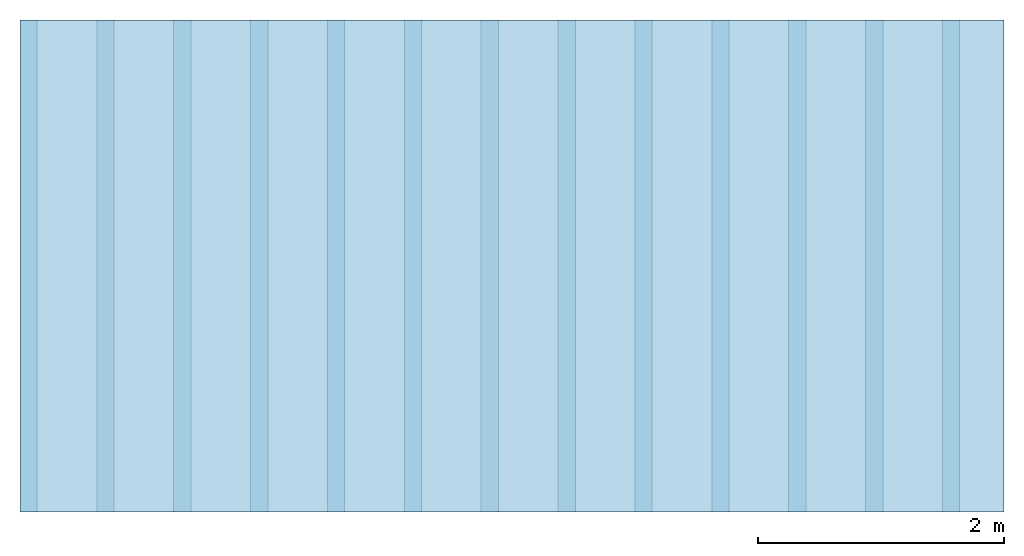
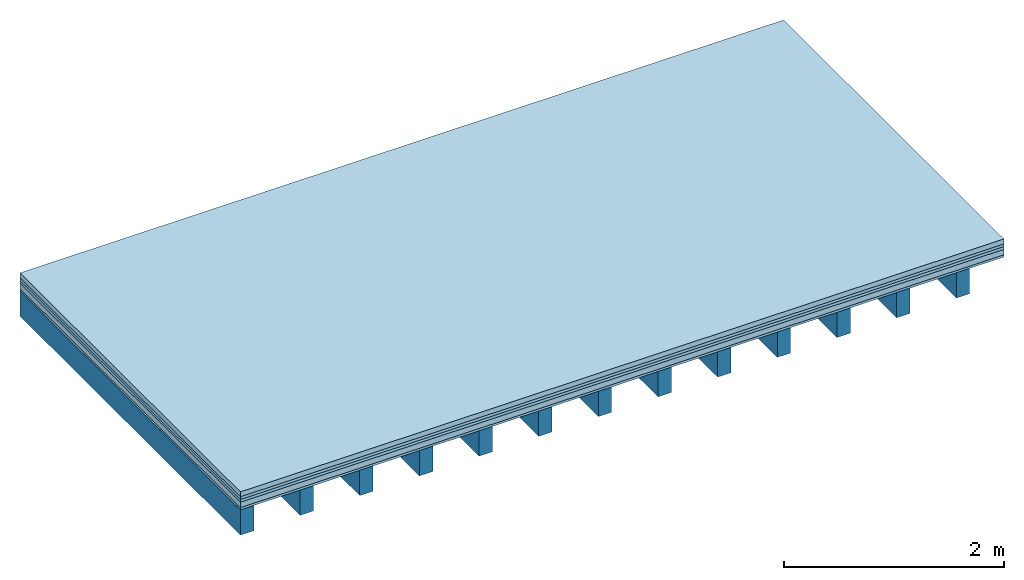
# One storey: 5 plates, 1 member, 1 element without a shape of its own.
"""IFC4 building model written with IfcOpenShell, lengths in metres."""

from ifc_helpers import new_model, si_unit, derived_unit, direction, frame, frame_2d, origin, origin_with_axes, place, context, project, spatial, rectangle, extrude, material, layer, layer_set, type_object, element, aggregate, save


model = new_model("IFC4")

# Units and contexts
plan_context = context("Plan", 3, precision=1e-05, world=origin(), true_north=direction((0.0, 1.0)))
model_context = context("Model", 3, precision=1e-05, world=origin(), true_north=direction((0.0, 1.0)))
ifc_project = project(units=[si_unit("LENGTHUNIT", "METRE"), derived_unit("SOUNDPRESSUREUNIT", [(si_unit("PRESSUREUNIT", "PASCAL", prefix="MICRO"), 0)]), si_unit("ENERGYUNIT", "JOULE", prefix="MEGA"), si_unit("MASSUNIT", "GRAM", prefix="KILO"), derived_unit("THERMALTRANSMITTANCEUNIT", [(si_unit("POWERUNIT", "WATT"), 1), (si_unit("AREAUNIT", "SQUARE_METRE"), -1), (si_unit("THERMODYNAMICTEMPERATUREUNIT", "KELVIN"), -1)]), derived_unit("AREADENSITYUNIT", [(si_unit("MASSUNIT", "GRAM", prefix="KILO"), 1), (si_unit("AREAUNIT", "SQUARE_METRE"), -1)]), derived_unit("USERDEFINED", [(si_unit("ENERGYUNIT", "JOULE", prefix="MEGA"), 1), (si_unit("AREAUNIT", "SQUARE_METRE"), -1)])], contexts=[plan_context, model_context])

# Site, building, storey
site = spatial("IfcSite", under=ifc_project)
building_placement = place(None, origin())
building = spatial("IfcBuilding", under=site, at=building_placement)
storey_placement = place(building_placement, origin())
storey = spatial("IfcBuildingStorey", under=building, at=storey_placement)

# Slab, member, plates
ifc_material_1 = material(Category="04.005")
ifc_layer_1 = layer(ifc_material_1, 0.055, Name="On-material")
ifc_material_2 = material()
ifc_layer_2 = layer(ifc_material_2, 0.03, Name="Impact sound insulation")
ifc_material_3 = material()
ifc_layer_3 = layer(ifc_material_3, 0.03, Name="Additional insulation")
ifc_material_4 = material(Name="Cement panels, glued on sub-floor", Category="02.007")
ifc_layer_4 = layer(ifc_material_4, 0.06, Name="on Supporting structure")
ifc_material_5 = material(Category="07.001")
ifc_layer_5 = layer(ifc_material_5, 0.025, Name="Sub-floor")
ifc_material_6 = material(Name="of the art")
ifc_layer_6 = layer(ifc_material_6, 0.0, Name="Bond")
ifc_layer_7 = layer(None, 0.28, Name="Supporting structure")
ifc_layer_set = layer_set([ifc_layer_1, ifc_layer_2, ifc_layer_3, ifc_layer_4, ifc_layer_5, ifc_layer_6, ifc_layer_7])
slab_type = type_object("IfcSlabType", Name="A0227", PredefinedType="NOTDEFINED", material=ifc_layer_set)
slab_placement = place(None, frame((0.0, 0.0, 0.0), z_axis=(0.0, 0.0, -1.0), x_axis=(1.0, 0.0, 0.0)))
slab = element("IfcSlab", 1, at=slab_placement, inside=storey, type_object=slab_type, material=ifc_layer_set, Name="Slab #1")
ifc_material_7 = material()
member_placement = place(slab_placement, origin())
member = element("IfcMember", 2, at=member_placement, material=ifc_material_7, Name="Supporting structure", context=plan_context, shape_type="SweptSolid", body=[
    extrude(rectangle(XDim=0.14, YDim=0.28, at=frame_2d((0.07, 0.14), x_axis=(1.0, 0.0))), frame((0.0, 4.0, 0.2), z_axis=(0.0, -1.0, 0.0), x_axis=(1.0, 0.0, 0.0)), (0.0, 0.0, 1.0), 4.0),
    extrude(rectangle(XDim=0.14, YDim=0.28, at=frame_2d((0.07, 0.14), x_axis=(1.0, 0.0))), frame((0.625, 4.0, 0.2), z_axis=(0.0, -1.0, 0.0), x_axis=(1.0, 0.0, 0.0)), (0.0, 0.0, 1.0), 4.0),
    extrude(rectangle(XDim=0.14, YDim=0.28, at=frame_2d((0.07, 0.14), x_axis=(1.0, 0.0))), frame((1.25, 4.0, 0.2), z_axis=(0.0, -1.0, 0.0), x_axis=(1.0, 0.0, 0.0)), (0.0, 0.0, 1.0), 4.0),
    extrude(rectangle(XDim=0.14, YDim=0.28, at=frame_2d((0.07, 0.14), x_axis=(1.0, 0.0))), frame((1.875, 4.0, 0.2), z_axis=(0.0, -1.0, 0.0), x_axis=(1.0, 0.0, 0.0)), (0.0, 0.0, 1.0), 4.0),
    extrude(rectangle(XDim=0.14, YDim=0.28, at=frame_2d((0.07, 0.14), x_axis=(1.0, 0.0))), frame((2.5, 4.0, 0.2), z_axis=(0.0, -1.0, 0.0), x_axis=(1.0, 0.0, 0.0)), (0.0, 0.0, 1.0), 4.0),
    extrude(rectangle(XDim=0.14, YDim=0.28, at=frame_2d((0.07, 0.14), x_axis=(1.0, 0.0))), frame((3.125, 4.0, 0.2), z_axis=(0.0, -1.0, 0.0), x_axis=(1.0, 0.0, 0.0)), (0.0, 0.0, 1.0), 4.0),
    extrude(rectangle(XDim=0.14, YDim=0.28, at=frame_2d((0.07, 0.14), x_axis=(1.0, 0.0))), frame((3.75, 4.0, 0.2), z_axis=(0.0, -1.0, 0.0), x_axis=(1.0, 0.0, 0.0)), (0.0, 0.0, 1.0), 4.0),
    extrude(rectangle(XDim=0.14, YDim=0.28, at=frame_2d((0.07, 0.14), x_axis=(1.0, 0.0))), frame((4.375, 4.0, 0.2), z_axis=(0.0, -1.0, 0.0), x_axis=(1.0, 0.0, 0.0)), (0.0, 0.0, 1.0), 4.0),
    extrude(rectangle(XDim=0.14, YDim=0.28, at=frame_2d((0.07, 0.14), x_axis=(1.0, 0.0))), frame((5.0, 4.0, 0.2), z_axis=(0.0, -1.0, 0.0), x_axis=(1.0, 0.0, 0.0)), (0.0, 0.0, 1.0), 4.0),
    extrude(rectangle(XDim=0.14, YDim=0.28, at=frame_2d((0.07, 0.14), x_axis=(1.0, 0.0))), frame((5.625, 4.0, 0.2), z_axis=(0.0, -1.0, 0.0), x_axis=(1.0, 0.0, 0.0)), (0.0, 0.0, 1.0), 4.0),
    extrude(rectangle(XDim=0.14, YDim=0.28, at=frame_2d((0.07, 0.14), x_axis=(1.0, 0.0))), frame((6.25, 4.0, 0.2), z_axis=(0.0, -1.0, 0.0), x_axis=(1.0, 0.0, 0.0)), (0.0, 0.0, 1.0), 4.0),
    extrude(rectangle(XDim=0.14, YDim=0.28, at=frame_2d((0.07, 0.14), x_axis=(1.0, 0.0))), frame((6.875, 4.0, 0.2), z_axis=(0.0, -1.0, 0.0), x_axis=(1.0, 0.0, 0.0)), (0.0, 0.0, 1.0), 4.0),
    extrude(rectangle(XDim=0.14, YDim=0.28, at=frame_2d((0.07, 0.14), x_axis=(1.0, 0.0))), frame((7.5, 4.0, 0.2), z_axis=(0.0, -1.0, 0.0), x_axis=(1.0, 0.0, 0.0)), (0.0, 0.0, 1.0), 4.0),
])
plate_1_placement = place(slab_placement, origin())
plate_1 = element("IfcPlate", 3, at=plate_1_placement, material=ifc_material_1, Name="On-material", context=plan_context, shape_type="SweptSolid", body=[
    extrude(rectangle(XDim=8.0, YDim=4.0, at=frame_2d((4.0, 2.0), x_axis=(1.0, 0.0))), origin_with_axes(), (0.0, 0.0, 1.0), 0.055),
])
plate_2_placement = place(slab_placement, origin())
plate_2 = element("IfcPlate", 4, at=plate_2_placement, material=ifc_material_2, Name="Impact sound insulation", context=plan_context, shape_type="SweptSolid", body=[
    extrude(rectangle(XDim=8.0, YDim=4.0, at=frame_2d((4.0, 2.0), x_axis=(1.0, 0.0))), frame((0.0, 0.0, 0.055), z_axis=(0.0, 0.0, 1.0), x_axis=(1.0, 0.0, 0.0)), (0.0, 0.0, 1.0), 0.03),
])
plate_3_placement = place(slab_placement, origin())
plate_3 = element("IfcPlate", 5, at=plate_3_placement, material=ifc_material_3, Name="Additional insulation", context=plan_context, shape_type="SweptSolid", body=[
    extrude(rectangle(XDim=8.0, YDim=4.0, at=frame_2d((4.0, 2.0), x_axis=(1.0, 0.0))), frame((0.0, 0.0, 0.085), z_axis=(0.0, 0.0, 1.0), x_axis=(1.0, 0.0, 0.0)), (0.0, 0.0, 1.0), 0.03),
])
plate_4_placement = place(slab_placement, origin())
plate_4 = element("IfcPlate", 6, at=plate_4_placement, material=ifc_material_4, Name="on Supporting structure", context=plan_context, shape_type="SweptSolid", body=[
    extrude(rectangle(XDim=8.0, YDim=4.0, at=frame_2d((4.0, 2.0), x_axis=(1.0, 0.0))), frame((0.0, 0.0, 0.115), z_axis=(0.0, 0.0, 1.0), x_axis=(1.0, 0.0, 0.0)), (0.0, 0.0, 1.0), 0.06),
])
plate_5_placement = place(slab_placement, origin())
plate_5 = element("IfcPlate", 7, at=plate_5_placement, material=ifc_material_5, Name="Sub-floor", context=plan_context, shape_type="SweptSolid", body=[
    extrude(rectangle(XDim=8.0, YDim=4.0, at=frame_2d((4.0, 2.0), x_axis=(1.0, 0.0))), frame((0.0, 0.0, 0.175), z_axis=(0.0, 0.0, 1.0), x_axis=(1.0, 0.0, 0.0)), (0.0, 0.0, 1.0), 0.025),
])
aggregate(slab, [plate_1, plate_2, plate_3, plate_4, plate_5, member])

save(model, "model.ifc")
